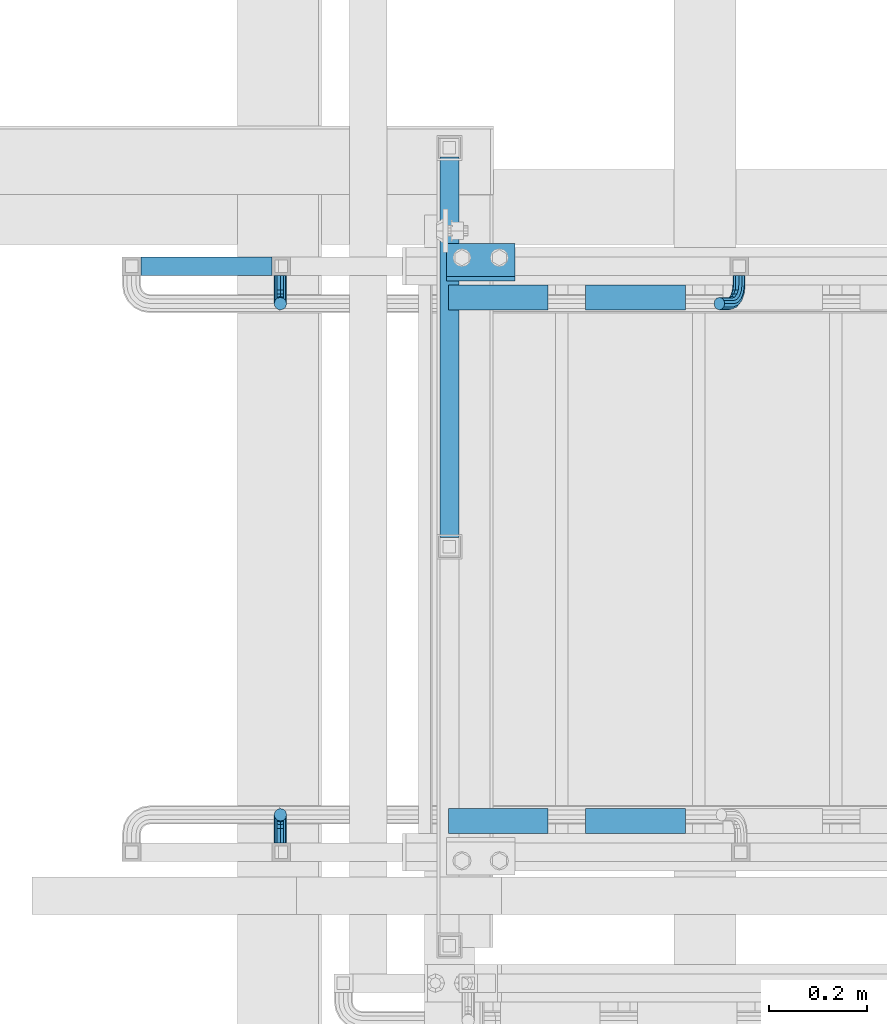
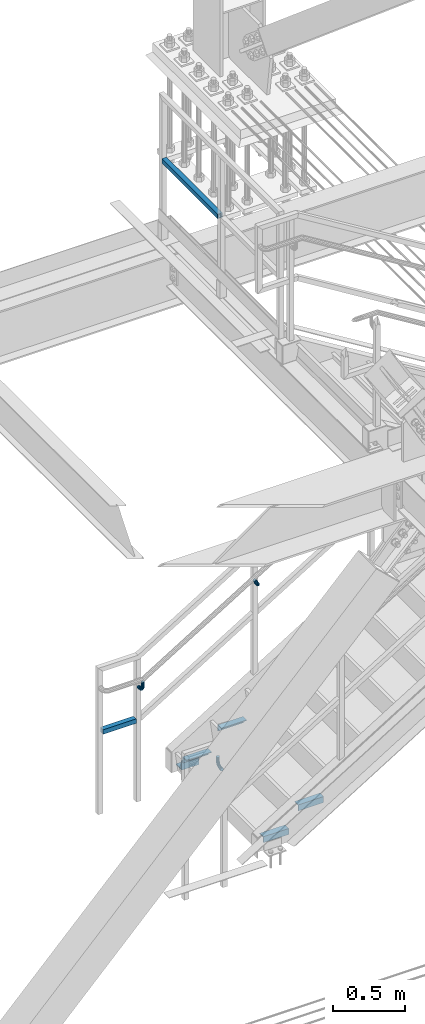
# One storey, part 2585 of 3843: 10 beams, 4 elements without a shape of their own.
"""IFC2X3 building model written with IfcOpenShell, lengths in millimetres."""

from ifc_helpers import new_model, si_unit, frame, origin_with_axes, place, context, subcontext, project, spatial, faceted_brep, material, type_object, element, aggregate, save


model = new_model("IFC2X3")

# Units and contexts
model_context = context("Model", 3, precision=1e-05, world=origin_with_axes())
body_context = subcontext(model_context, "Body", "Model", "MODEL_VIEW")
ifc_project = project(units=[si_unit("LENGTHUNIT", "METRE", prefix="MILLI"), si_unit("AREAUNIT", "SQUARE_METRE"), si_unit("VOLUMEUNIT", "CUBIC_METRE"), si_unit("MASSUNIT", "GRAM", prefix="KILO"), si_unit("TIMEUNIT", "SECOND"), si_unit("PLANEANGLEUNIT", "RADIAN"), si_unit("SOLIDANGLEUNIT", "STERADIAN"), si_unit("THERMODYNAMICTEMPERATUREUNIT", "DEGREE_CELSIUS"), si_unit("LUMINOUSINTENSITYUNIT", "LUMEN")], contexts=[model_context])

# Site, building, storey
site_placement = place(None, origin_with_axes())
site = spatial("IfcSite", under=ifc_project, at=site_placement, CompositionType="ELEMENT")
building_placement = place(site_placement, origin_with_axes())
building = spatial("IfcBuilding", under=site, at=building_placement, Name="Undefined", CompositionType="ELEMENT")
storey_placement = place(building_placement, origin_with_axes())
storey = spatial("IfcBuildingStorey", under=building, at=storey_placement, Name="Undefined", CompositionType="ELEMENT", Elevation=0.0)

# Assembly, beam
assembly_1_placement = place(storey_placement, origin_with_axes())
assembly_1 = element("IfcElementAssembly", 1, at=assembly_1_placement, inside=storey, Name="STAIR", AssemblyPlace="NOTDEFINED", PredefinedType="RIGID_FRAME")
ifc_material_1 = material(Name="STEEL/A36")
beam_type_1 = type_object("IfcBeamType", Name="L3X3X3/8", PredefinedType="NOTDEFINED")
beam_1_placement = place(assembly_1_placement, frame((80803.7500000127, 17927.6375000062, 30518.1), z_axis=(0.0, 1.0, 0.0), x_axis=(1.0, 0.0, 0.0)))
beam_1 = element("IfcBeam", 2, at=beam_1_placement, type_object=beam_type_1, material=ifc_material_1, Name="CLEAT", ObjectType="L3X3X3/8", context=body_context, shape_type="Brep", body=[
    faceted_brep([(0.0, 38.0999999999985, -38.0999999999985), (0.0, 38.0999999999985, 38.0999999999985), (139.699999999997, 38.0999999999985, 38.0999999999985), (139.699999999997, 38.0999999999985, -38.0999999999985), (0.0, 28.5750000000007, 38.0999999999985), (139.699999999997, 28.5750000000007, 38.0999999999985), (0.0, 28.5750000000007, -28.5750000000007), (139.699999999997, 28.5750000000007, -28.5750000000007), (0.0, -38.0999999999985, -28.5750000000007), (139.699999999997, -38.0999999999985, -28.5750000000007), (0.0, -38.0999999999985, -38.0999999999985), (139.699999999997, -38.0999999999985, -38.0999999999985)], [[[0, 1, 2, 3]], [[1, 4, 5, 2]], [[4, 6, 7, 5]], [[6, 8, 9, 7]], [[8, 10, 11, 9]], [[10, 0, 3, 11]], [[5, 7, 9, 11, 3, 2]], [[10, 8, 6, 4, 1, 0]]]),
])

assembly_2_placement = place(storey_placement, origin_with_axes())
assembly_2 = element("IfcElementAssembly", 3, at=assembly_2_placement, inside=storey, Name="RAIL", AssemblyPlace="NOTDEFINED", PredefinedType="RIGID_FRAME")
ifc_material_2 = material()
beam_type_2 = type_object("IfcBeamType", Name="HSS1-1/2X1-1/2X1/4", PredefinedType="NOTDEFINED")
beam_2_placement = place(assembly_2_placement, frame((80162.3999999998, 17919.7, 31013.4000000001), z_axis=(0.0, 0.0, 1.0), x_axis=(1.0, 0.0, 0.0)))
beam_2 = element("IfcBeam", 4, at=beam_2_placement, type_object=beam_type_2, material=ifc_material_2, Name="RAIL", ObjectType="HSS1-1/2X1-1/2X1/4", context=body_context, shape_type="Brep", body=[
    faceted_brep([(285.750000765285, -19.0499992350015, 19.0499992350015), (285.750000765285, -19.0499992350015, -19.0499992350015), (285.750000765285, 19.0499992350015, -19.0499992350015), (285.750000765285, 19.0499992350015, 19.0499992350015), (285.750000765009, -12.6999993300014, 12.6999993299978), (285.750000765009, 12.6999993300014, 12.6999993299978), (285.750000765009, 12.6999993300014, -12.6999993299978), (285.750000765009, -12.6999993300014, -12.6999993299978), (19.0499992350015, 19.0499992350015, -19.0499992350015), (19.0499992350015, 19.0499992350015, 19.0499992350015), (19.0499992350015, -19.0499992350015, 19.0499992350015), (19.0499992350015, -19.0499992350015, -19.0499992350015), (19.0499992350015, 12.6999993299978, 12.6999993299978), (19.0499992350015, -12.6999993299978, 12.6999993299978), (19.0499992350015, -12.6999993299978, -12.6999993299978), (19.0499992350015, 12.6999993299978, -12.6999993299978)], [[[0, 1, 2, 3], [4, 5, 6, 7]], [[8, 9, 3, 2]], [[9, 10, 0, 3]], [[10, 11, 1, 0]], [[11, 8, 2, 1]], [[11, 10, 9, 8], [12, 13, 14, 15]], [[14, 13, 4, 7]], [[15, 14, 7, 6]], [[12, 15, 6, 5]], [[13, 12, 5, 4]]]),
])

assembly_3_placement = place(storey_placement, origin_with_axes())
assembly_3 = element("IfcElementAssembly", 5, at=assembly_3_placement, inside=storey, Name="RAIL", AssemblyPlace="NOTDEFINED", PredefinedType="RIGID_FRAME")
beam_3_placement = place(assembly_3_placement, frame((80810.1, 18167.35, 35483.8), z_axis=(0.0, 0.0, 1.0), x_axis=(0.0, -1.0, 0.0)))
beam_3 = element("IfcBeam", 6, at=beam_3_placement, type_object=beam_type_2, material=ifc_material_2, Name="RAIL", ObjectType="HSS1-1/2X1-1/2X1/4", context=body_context, shape_type="Brep", body=[
    faceted_brep([(800.100000765, -19.0499992349942, 19.0499992350015), (800.100000765, -19.0499992349942, -19.0499992350015), (800.100000765, 19.0499992349942, -19.0499992350015), (800.100000765, 19.0499992349942, 19.0499992350015), (800.100000765, -12.6999993299978, 12.6999993299978), (800.100000765, 12.6999993299978, 12.6999993299978), (800.100000765, 12.6999993299978, -12.6999993299978), (800.100000765, -12.6999993299978, -12.6999993299978), (25.4000000135893, 19.0499992350015, 19.0499992349942), (25.4000000135893, -19.0499992350015, 19.0499992349942), (25.4000000135893, -19.0499992350015, -19.0499992349942), (25.4000000135893, 19.0499992350015, -19.0499992349942), (25.4000000135893, 12.6999993300014, -12.6999993299978), (25.4000000135893, 12.6999993300014, 12.6999993299978), (25.4000000135893, -12.6999993300014, 12.6999993299978), (25.4000000135893, -12.6999993300014, -12.6999993299978)], [[[0, 1, 2, 3], [4, 5, 6, 7]], [[8, 9, 0, 3]], [[10, 11, 2, 1]], [[9, 10, 1, 0]], [[11, 8, 3, 2]], [[11, 10, 9, 8], [12, 13, 14, 15]], [[15, 14, 4, 7]], [[12, 15, 7, 6]], [[13, 12, 6, 5]], [[14, 13, 5, 4]]]),
])
aggregate(assembly_3, [beam_3])

# Beam
ifc_material_3 = material(Name="STEEL/A572-50")
beam_type_3 = type_object("IfcBeamType", Name="L2X2X3/16", PredefinedType="NOTDEFINED")
beam_4_placement = place(assembly_1_placement, frame((81087.5140030505, 17856.1999999907, 30744.5019230761), z_axis=(0.0, -1.0, 0.0), x_axis=(1.0, 0.0, 0.0)))
beam_4 = element("IfcBeam", 7, at=beam_4_placement, type_object=beam_type_3, material=ifc_material_3, Name="ANGLE", ObjectType="L2X2X3/16", context=body_context, shape_type="Brep", body=[
    faceted_brep([(0.0, 25.4000000000015, -25.4000000000015), (0.0, 25.4000000000015, 25.4000000000015), (203.199999999997, 25.4000000000015, 25.4000000000015), (203.199999999997, 25.4000000000015, -25.4000000000015), (0.0, 20.6375000000007, 25.4000000000015), (203.199999999997, 20.6375000000007, 25.4000000000015), (0.0, 20.6375000000007, -20.6375000000007), (203.199999999997, 20.6375000000007, -20.6375000000007), (0.0, -25.4000000000015, -20.6375000000007), (203.199999999997, -25.4000000000015, -20.6375000000007), (0.0, -25.4000000000015, -25.4000000000015), (203.199999999997, -25.4000000000015, -25.4000000000015)], [[[0, 1, 2, 3]], [[1, 4, 5, 2]], [[4, 6, 7, 5]], [[6, 8, 9, 7]], [[8, 10, 11, 9]], [[10, 0, 3, 11]], [[5, 7, 9, 11, 3, 2]], [[10, 8, 6, 4, 1, 0]]]),
])

beam_5_placement = place(assembly_1_placement, frame((81290.7140030505, 16789.3999999318, 30744.5019230761), z_axis=(0.0, 1.0, 0.0), x_axis=(-1.0, 0.0, 0.0)))
beam_5 = element("IfcBeam", 8, at=beam_5_placement, type_object=beam_type_3, material=ifc_material_3, Name="ANGLE", ObjectType="L2X2X3/16", context=body_context, shape_type="Brep", body=[
    faceted_brep([(0.0, 25.4000000000015, -25.4000000000015), (0.0, 25.4000000000015, 25.4000000000015), (203.199999999997, 25.4000000000015, 25.4000000000015), (203.199999999997, 25.4000000000015, -25.4000000000015), (0.0, 20.6375000000007, 25.4000000000015), (203.199999999997, 20.6375000000007, 25.4000000000015), (0.0, 20.6375000000007, -20.6375000000007), (203.199999999997, 20.6375000000007, -20.6375000000007), (0.0, -25.4000000000015, -20.6375000000007), (203.199999999997, -25.4000000000015, -20.6375000000007), (0.0, -25.4000000000015, -25.4000000000015), (203.199999999997, -25.4000000000015, -25.4000000000015)], [[[0, 1, 2, 3]], [[1, 4, 5, 2]], [[4, 6, 7, 5]], [[6, 8, 9, 7]], [[8, 10, 11, 9]], [[10, 0, 3, 11]], [[5, 7, 9, 11, 3, 2]], [[10, 8, 6, 4, 1, 0]]]),
])

beam_6_placement = place(assembly_1_placement, frame((80808.1140030505, 17856.1999999907, 30572.5634615376), z_axis=(0.0, -1.0, 0.0), x_axis=(1.0, 0.0, 0.0)))
beam_6 = element("IfcBeam", 9, at=beam_6_placement, type_object=beam_type_3, material=ifc_material_3, Name="ANGLE", ObjectType="L2X2X3/16", context=body_context, shape_type="Brep", body=[
    faceted_brep([(0.0, 25.4000000000015, -25.4000000000015), (0.0, 25.4000000000015, 25.4000000000015), (203.199999999997, 25.4000000000015, 25.4000000000015), (203.199999999997, 25.4000000000015, -25.4000000000015), (0.0, 20.6375000000007, 25.4000000000015), (203.199999999997, 20.6375000000007, 25.4000000000015), (0.0, 20.6375000000007, -20.6375000000007), (203.199999999997, 20.6375000000007, -20.6375000000007), (0.0, -25.4000000000015, -20.6375000000007), (203.199999999997, -25.4000000000015, -20.6375000000007), (0.0, -25.4000000000015, -25.4000000000015), (203.199999999997, -25.4000000000015, -25.4000000000015)], [[[0, 1, 2, 3]], [[1, 4, 5, 2]], [[4, 6, 7, 5]], [[6, 8, 9, 7]], [[8, 10, 11, 9]], [[10, 0, 3, 11]], [[5, 7, 9, 11, 3, 2]], [[10, 8, 6, 4, 1, 0]]]),
])

beam_7_placement = place(assembly_1_placement, frame((81011.3140030505, 16789.3999999317, 30572.5634615376), z_axis=(0.0, 1.0, 0.0), x_axis=(-1.0, 0.0, 0.0)))
beam_7 = element("IfcBeam", 10, at=beam_7_placement, type_object=beam_type_3, material=ifc_material_3, Name="ANGLE", ObjectType="L2X2X3/16", context=body_context, shape_type="Brep", body=[
    faceted_brep([(0.0, 25.4000000000015, -25.4000000000015), (0.0, 25.4000000000015, 25.4000000000015), (203.199999999997, 25.4000000000015, 25.4000000000015), (203.199999999997, 25.4000000000015, -25.4000000000015), (0.0, 20.6375000000007, 25.4000000000015), (203.199999999997, 20.6375000000007, 25.4000000000015), (0.0, 20.6375000000007, -20.6375000000007), (203.199999999997, 20.6375000000007, -20.6375000000007), (0.0, -25.4000000000015, -20.6375000000007), (203.199999999997, -25.4000000000015, -20.6375000000007), (0.0, -25.4000000000015, -25.4000000000015), (203.199999999997, -25.4000000000015, -25.4000000000015)], [[[0, 1, 2, 3]], [[1, 4, 5, 2]], [[4, 6, 7, 5]], [[6, 8, 9, 7]], [[8, 10, 11, 9]], [[10, 0, 3, 11]], [[5, 7, 9, 11, 3, 2]], [[10, 8, 6, 4, 1, 0]]]),
])

aggregate(assembly_1, [beam_1, beam_4, beam_5, beam_6, beam_7])

beam_type_4 = type_object("IfcBeamType", PredefinedType="NOTDEFINED")
beam_8_placement = place(assembly_2_placement, frame((81399.9812276889, 17900.65, 31856.5785901979), z_axis=(-0.851658316635875, 0.0, -0.524097425775922), x_axis=(0.0, -1.0, 0.0)))
beam_8 = element("IfcBeam", 11, at=beam_8_placement, type_object=beam_type_4, material=ifc_material_1, Name="BRACKET ARM", context=body_context, shape_type="Brep", body=[
    faceted_brep([(0.0, -12.6999999999971, 0.0), (0.0, -10.9985226280696, -6.34999999999854), (19.0500015258731, -10.9985226280623, -6.34999999999854), (19.0500015258731, -12.6999999999971, -6.33008312433958e-10), (0.0, -6.35000000000582, -10.9985226280623), (19.0500015258731, -6.34999999999854, -10.9985226280623), (0.0, 0.0, -12.6999999999971), (19.0500015258731, 0.0, -12.6999999999971), (0.0, 6.35000000000582, -10.9985226280623), (19.0500015258731, 6.34999999999854, -10.9985226280623), (0.0, 10.9985226280696, -6.34999999999854), (19.0500015258731, 10.9985226280623, -6.34999999999854), (0.0, 12.6999999999971, 0.0), (19.0500015258731, 12.6999999999971, 0.0), (0.0, 10.9985226280696, 6.34999999999854), (19.0500015258731, 10.9985226280623, 6.34999999999854), (0.0, 6.35000000000582, 10.9985226280623), (19.0500015258731, 6.34999999999854, 10.9985226280623), (0.0, 0.0, 12.6999999999971), (19.0500015258731, 0.0, 12.6999999999971), (0.0, -6.35000000000582, 10.9985226280623), (19.0500015258731, -6.34999999999854, 10.9985226280623), (0.0, -10.9985226280696, 6.34999999999854), (19.0500015258731, -10.9985226280623, 6.34999999999854), (38.4903193060891, -8.8330803677236, -3.34694050252438e-10), (37.8391921052389, -7.26112024908798, 6.34999999974389), (36.0602795104642, -2.96644533684594, 10.9985226280041), (33.6302397149266, 2.90018969451194, 12.7000000002226), (31.2001999194181, 8.76682472604443, 10.9985226285644), (29.4212873247307, 13.061499638774, 6.35000000070431), (28.7701601240115, 14.6334597580644, 7.78527464717627e-10), (29.4212873248762, 13.0614996394288, -6.34999999929278), (31.2001999196509, 8.76682472718676, -10.9985226275603), (33.6302397151885, 2.90018969582889, -12.6999999997788), (36.0602795106824, -2.96644533571089, -10.9985226281206), (37.8391921053699, -7.26112024843314, -6.35000000026048), (53.7678987435793, 3.38210125690239, -6.3499999994383), (54.9710249311902, 2.17897506880399, 5.0931703299284e-10), (50.4808968708676, 6.66910312997061, -10.9985226273784), (45.9907688103704, 11.1592311906061, -12.6999999991458), (41.5006407498004, 15.6493592510378, -10.9985226270364), (38.213638876914, 18.9363611235749, -6.34999999884167), (37.0105126890558, 20.1394873109457, 1.20053300634027e-09), (38.2136388766667, 18.9363611228473, 6.35000000115542), (41.5006407493784, 15.6493592497718, 10.9985226290883), (45.9907688098756, 11.1592311891436, 12.7000000008557), (50.4808968704456, 6.66910312870459, 10.9985226287463), (53.7678987433319, 3.38210125617479, 6.35000000055879), (64.4111202489148, 19.3108078951118, -6.34999999821594), (65.9830803677178, 18.6596806939051, 1.77533365786076e-09), (60.1164453365491, 21.0897204901557, -10.9985226262725), (54.2498103051475, 23.5197602857806, -12.6999999981927), (48.3831752736587, 25.9498000811873, -10.9985226262434), (44.0885003610601, 27.7287126756128, -6.34999999817228), (42.516540241937, 28.3798398759754, 1.83354131877422e-09), (44.08850036074, 27.7287126747688, 6.35000000183209), (48.3831752731057, 25.9498000797321, 10.9985226298813), (54.2498103045073, 23.5197602840999, 12.7000000018088), (60.1164453359961, 21.0897204886933, 10.9985226298522), (64.4111202485947, 19.3108078942678, 6.35000000178115), (68.1485226282239, 38.0999984746086, -6.3499999967753), (69.8499999999913, 38.0999984741211, 2.92493496090174e-09), (63.500000000291, 38.0999984749651, -10.9985226249628), (57.1500000003434, 38.0999984750961, -12.6999999970722), (50.8000000002939, 38.0999984749651, -10.998522625312), (46.1514773720992, 38.0999984746086, -6.34999999737192), (44.4499999999971, 38.0999984741211, 2.58296495303512e-09), (46.1514773717645, 38.0999984736336, 6.35000000262517), (50.7999999996973, 38.0999984732771, 10.9985226308127), (57.1499999996449, 38.0999984731461, 12.700000002922), (63.4999999996944, 38.0999984732771, 10.9985226311619), (68.1485226278892, 38.0999984736336, 6.35000000322179), (68.1485226280638, 76.2000000002372, -6.34999999414867), (69.8499999999913, 76.199999999757, 5.84986992180347e-09), (63.5, 76.200000000601, -10.9985226222125), (57.1499999999942, 76.2000000007247, -12.6999999941472), (50.7999999999884, 76.200000000601, -10.9985226222125), (46.1514773719246, 76.2000000002372, -6.34999999414867), (44.4499999999971, 76.199999999757, 5.84986992180347e-09), (46.1514773719246, 76.1999999992695, 6.35000000584841), (50.7999999999884, 76.1999999989057, 10.9985226339122), (57.1499999999942, 76.199999998782, 12.700000005847), (63.5, 76.1999999989057, 10.9985226339122), (68.1485226280638, 76.1999999992695, 6.35000000584841)], [[[0, 1, 2, 3]], [[1, 4, 5, 2]], [[4, 6, 7, 5]], [[6, 8, 9, 7]], [[8, 10, 11, 9]], [[10, 12, 13, 11]], [[12, 14, 15, 13]], [[14, 16, 17, 15]], [[16, 18, 19, 17]], [[18, 20, 21, 19]], [[20, 22, 23, 21]], [[22, 0, 3, 23]], [[22, 20, 18, 16, 14, 12, 10, 8, 6, 4, 1, 0]], [[23, 3, 24, 25]], [[21, 23, 25, 26]], [[19, 21, 26, 27]], [[17, 19, 27, 28]], [[15, 17, 28, 29]], [[13, 15, 29, 30]], [[11, 13, 30, 31]], [[9, 11, 31, 32]], [[7, 9, 32, 33]], [[5, 7, 33, 34]], [[2, 5, 34, 35]], [[3, 2, 35, 24]], [[35, 36, 37, 24]], [[34, 38, 36, 35]], [[33, 39, 38, 34]], [[32, 40, 39, 33]], [[31, 41, 40, 32]], [[30, 42, 41, 31]], [[29, 43, 42, 30]], [[28, 44, 43, 29]], [[27, 45, 44, 28]], [[26, 46, 45, 27]], [[25, 47, 46, 26]], [[24, 37, 47, 25]], [[36, 48, 49, 37]], [[38, 50, 48, 36]], [[39, 51, 50, 38]], [[40, 52, 51, 39]], [[41, 53, 52, 40]], [[42, 54, 53, 41]], [[43, 55, 54, 42]], [[44, 56, 55, 43]], [[45, 57, 56, 44]], [[46, 58, 57, 45]], [[47, 59, 58, 46]], [[37, 49, 59, 47]], [[48, 60, 61, 49]], [[50, 62, 60, 48]], [[51, 63, 62, 50]], [[52, 64, 63, 51]], [[53, 65, 64, 52]], [[54, 66, 65, 53]], [[55, 67, 66, 54]], [[56, 68, 67, 55]], [[57, 69, 68, 56]], [[58, 70, 69, 57]], [[59, 71, 70, 58]], [[49, 61, 71, 59]], [[61, 60, 72, 73]], [[60, 62, 74, 72]], [[62, 63, 75, 74]], [[63, 64, 76, 75]], [[64, 65, 77, 76]], [[65, 66, 78, 77]], [[66, 67, 79, 78]], [[67, 68, 80, 79]], [[68, 69, 81, 80]], [[69, 70, 82, 81]], [[70, 71, 83, 82]], [[71, 61, 73, 83]], [[74, 75, 76, 77, 78, 79, 80, 81, 82, 83, 73, 72]]]),
])

beam_9_placement = place(assembly_2_placement, frame((80465.6124994492, 17900.65, 31299.15), z_axis=(-1.0, 0.0, 0.0), x_axis=(0.0, -1.0, 0.0)))
beam_9 = element("IfcBeam", 12, at=beam_9_placement, type_object=beam_type_4, material=ifc_material_1, Name="BRACKET ARM", context=body_context, shape_type="Brep", body=[
    faceted_brep([(0.0, -12.6999999999971, 0.0), (0.0, -10.9985226280696, -6.34999999999854), (19.0500015258731, -10.9985226280623, -6.34999999999854), (19.0500015258731, -12.6999999999971, -6.33008312433958e-10), (0.0, -6.35000000000582, -10.9985226280623), (19.0500015258731, -6.34999999999854, -10.9985226280623), (0.0, 0.0, -12.6999999999971), (19.0500015258731, 0.0, -12.6999999999971), (0.0, 6.35000000000582, -10.9985226280623), (19.0500015258731, 6.34999999999854, -10.9985226280623), (0.0, 10.9985226280696, -6.34999999999854), (19.0500015258731, 10.9985226280623, -6.34999999999854), (0.0, 12.6999999999971, 0.0), (19.0500015258731, 12.6999999999971, 0.0), (0.0, 10.9985226280696, 6.34999999999854), (19.0500015258731, 10.9985226280623, 6.34999999999854), (0.0, 6.35000000000582, 10.9985226280623), (19.0500015258731, 6.34999999999854, 10.9985226280623), (0.0, 0.0, 12.6999999999971), (19.0500015258731, 0.0, 12.6999999999971), (0.0, -6.35000000000582, 10.9985226280623), (19.0500015258731, -6.34999999999854, 10.9985226280623), (0.0, -10.9985226280696, 6.34999999999854), (19.0500015258731, -10.9985226280623, 6.34999999999854), (38.4903193060891, -8.8330803677236, -3.34694050252438e-10), (37.8391921052389, -7.26112024908798, 6.34999999974389), (36.0602795104642, -2.96644533684594, 10.9985226280041), (33.6302397149266, 2.90018969451194, 12.7000000002226), (31.2001999194181, 8.76682472604443, 10.9985226285644), (29.4212873247307, 13.061499638774, 6.35000000070431), (28.7701601240115, 14.6334597580644, 7.78527464717627e-10), (29.4212873248762, 13.0614996394288, -6.34999999929278), (31.2001999196509, 8.76682472718676, -10.9985226275603), (33.6302397151885, 2.90018969582889, -12.6999999997788), (36.0602795106824, -2.96644533571089, -10.9985226281206), (37.8391921053699, -7.26112024843314, -6.35000000026048), (53.7678987435793, 3.38210125690239, -6.3499999994383), (54.9710249311902, 2.17897506880399, 5.0931703299284e-10), (50.4808968708676, 6.66910312997061, -10.9985226273784), (45.9907688103704, 11.1592311906061, -12.6999999991458), (41.5006407498004, 15.6493592510378, -10.9985226270364), (38.213638876914, 18.9363611235749, -6.34999999884167), (37.0105126890558, 20.1394873109457, 1.20053300634027e-09), (38.2136388766667, 18.9363611228473, 6.35000000115542), (41.5006407493784, 15.6493592497718, 10.9985226290883), (45.9907688098756, 11.1592311891436, 12.7000000008557), (50.4808968704456, 6.66910312870459, 10.9985226287463), (53.7678987433319, 3.38210125617479, 6.35000000055879), (64.4111202489148, 19.3108078951118, -6.34999999821594), (65.9830803677178, 18.6596806939051, 1.77533365786076e-09), (60.1164453365491, 21.0897204901557, -10.9985226262725), (54.2498103051475, 23.5197602857806, -12.6999999981927), (48.3831752736587, 25.9498000811873, -10.9985226262434), (44.0885003610601, 27.7287126756128, -6.34999999817228), (42.516540241937, 28.3798398759754, 1.83354131877422e-09), (44.08850036074, 27.7287126747688, 6.35000000183209), (48.3831752731057, 25.9498000797321, 10.9985226298813), (54.2498103045073, 23.5197602840999, 12.7000000018088), (60.1164453359961, 21.0897204886933, 10.9985226298522), (64.4111202485947, 19.3108078942678, 6.35000000178115), (68.1485226282239, 38.0999984746086, -6.3499999967753), (69.8499999999913, 38.0999984741211, 2.92493496090174e-09), (63.500000000291, 38.0999984749651, -10.9985226249628), (57.1500000003434, 38.0999984750961, -12.6999999970722), (50.8000000002939, 38.0999984749651, -10.998522625312), (46.1514773720992, 38.0999984746086, -6.34999999737192), (44.4499999999971, 38.0999984741211, 2.58296495303512e-09), (46.1514773717645, 38.0999984736336, 6.35000000262517), (50.7999999996973, 38.0999984732771, 10.9985226308127), (57.1499999996449, 38.0999984731461, 12.700000002922), (63.4999999996944, 38.0999984732771, 10.9985226311619), (68.1485226278892, 38.0999984736336, 6.35000000322179), (68.1485226280638, 76.2000000002372, -6.34999999414867), (69.8499999999913, 76.199999999757, 5.84986992180347e-09), (63.5, 76.200000000601, -10.9985226222125), (57.1499999999942, 76.2000000007247, -12.6999999941472), (50.7999999999884, 76.200000000601, -10.9985226222125), (46.1514773719246, 76.2000000002372, -6.34999999414867), (44.4499999999971, 76.199999999757, 5.84986992180347e-09), (46.1514773719246, 76.1999999992695, 6.35000000584841), (50.7999999999884, 76.1999999989057, 10.9985226339122), (57.1499999999942, 76.199999998782, 12.700000005847), (63.5, 76.1999999989057, 10.9985226339122), (68.1485226280638, 76.1999999992695, 6.35000000584841)], [[[0, 1, 2, 3]], [[1, 4, 5, 2]], [[4, 6, 7, 5]], [[6, 8, 9, 7]], [[8, 10, 11, 9]], [[10, 12, 13, 11]], [[12, 14, 15, 13]], [[14, 16, 17, 15]], [[16, 18, 19, 17]], [[18, 20, 21, 19]], [[20, 22, 23, 21]], [[22, 0, 3, 23]], [[22, 20, 18, 16, 14, 12, 10, 8, 6, 4, 1, 0]], [[23, 3, 24, 25]], [[21, 23, 25, 26]], [[19, 21, 26, 27]], [[17, 19, 27, 28]], [[15, 17, 28, 29]], [[13, 15, 29, 30]], [[11, 13, 30, 31]], [[9, 11, 31, 32]], [[7, 9, 32, 33]], [[5, 7, 33, 34]], [[2, 5, 34, 35]], [[3, 2, 35, 24]], [[35, 36, 37, 24]], [[34, 38, 36, 35]], [[33, 39, 38, 34]], [[32, 40, 39, 33]], [[31, 41, 40, 32]], [[30, 42, 41, 31]], [[29, 43, 42, 30]], [[28, 44, 43, 29]], [[27, 45, 44, 28]], [[26, 46, 45, 27]], [[25, 47, 46, 26]], [[24, 37, 47, 25]], [[36, 48, 49, 37]], [[38, 50, 48, 36]], [[39, 51, 50, 38]], [[40, 52, 51, 39]], [[41, 53, 52, 40]], [[42, 54, 53, 41]], [[43, 55, 54, 42]], [[44, 56, 55, 43]], [[45, 57, 56, 44]], [[46, 58, 57, 45]], [[47, 59, 58, 46]], [[37, 49, 59, 47]], [[48, 60, 61, 49]], [[50, 62, 60, 48]], [[51, 63, 62, 50]], [[52, 64, 63, 51]], [[53, 65, 64, 52]], [[54, 66, 65, 53]], [[55, 67, 66, 54]], [[56, 68, 67, 55]], [[57, 69, 68, 56]], [[58, 70, 69, 57]], [[59, 71, 70, 58]], [[49, 61, 71, 59]], [[61, 60, 72, 73]], [[60, 62, 74, 72]], [[62, 63, 75, 74]], [[63, 64, 76, 75]], [[64, 65, 77, 76]], [[65, 66, 78, 77]], [[66, 67, 79, 78]], [[67, 68, 80, 79]], [[68, 69, 81, 80]], [[69, 70, 82, 81]], [[70, 71, 83, 82]], [[71, 61, 73, 83]], [[74, 75, 76, 77, 78, 79, 80, 81, 82, 83, 73, 72]]]),
])

aggregate(assembly_2, [beam_2, beam_8, beam_9])

# Assembly, beam
assembly_4_placement = place(storey_placement, origin_with_axes())
assembly_4 = element("IfcElementAssembly", 13, at=assembly_4_placement, inside=storey, Name="RAIL", AssemblyPlace="NOTDEFINED", PredefinedType="RIGID_FRAME")
beam_10_placement = place(assembly_4_placement, frame((80465.6124994492, 16744.95, 31299.15), z_axis=(1.0, 0.0, 0.0), x_axis=(0.0, 1.0, 0.0)))
beam_10 = element("IfcBeam", 14, at=beam_10_placement, type_object=beam_type_4, material=ifc_material_1, Name="BRACKET ARM", context=body_context, shape_type="Brep", body=[
    faceted_brep([(0.0, -12.6999999999971, 0.0), (0.0, -10.9985226280696, -6.34999999999854), (19.0500015258731, -10.9985226280623, -6.34999999999854), (19.0500015258731, -12.6999999999971, -6.33008312433958e-10), (0.0, -6.35000000000582, -10.9985226280623), (19.0500015258731, -6.34999999999854, -10.9985226280623), (0.0, 0.0, -12.6999999999971), (19.0500015258731, 0.0, -12.6999999999971), (0.0, 6.35000000000582, -10.9985226280623), (19.0500015258731, 6.34999999999854, -10.9985226280623), (0.0, 10.9985226280696, -6.34999999999854), (19.0500015258731, 10.9985226280623, -6.34999999999854), (0.0, 12.6999999999971, 0.0), (19.0500015258731, 12.6999999999971, 0.0), (0.0, 10.9985226280696, 6.34999999999854), (19.0500015258731, 10.9985226280623, 6.34999999999854), (0.0, 6.35000000000582, 10.9985226280623), (19.0500015258731, 6.34999999999854, 10.9985226280623), (0.0, 0.0, 12.6999999999971), (19.0500015258731, 0.0, 12.6999999999971), (0.0, -6.35000000000582, 10.9985226280623), (19.0500015258731, -6.34999999999854, 10.9985226280623), (0.0, -10.9985226280696, 6.34999999999854), (19.0500015258731, -10.9985226280623, 6.34999999999854), (38.4903193060891, -8.8330803677236, -3.34694050252438e-10), (37.8391921052389, -7.26112024908798, 6.34999999974389), (36.0602795104642, -2.96644533684594, 10.9985226280041), (33.6302397149266, 2.90018969451194, 12.7000000002226), (31.2001999194181, 8.76682472604443, 10.9985226285644), (29.4212873247307, 13.061499638774, 6.35000000070431), (28.7701601240115, 14.6334597580644, 7.78527464717627e-10), (29.4212873248762, 13.0614996394288, -6.34999999929278), (31.2001999196509, 8.76682472718676, -10.9985226275603), (33.6302397151885, 2.90018969582889, -12.6999999997788), (36.0602795106824, -2.96644533571089, -10.9985226281206), (37.8391921053699, -7.26112024843314, -6.35000000026048), (53.7678987435793, 3.38210125690239, -6.3499999994383), (54.9710249311902, 2.17897506880399, 5.0931703299284e-10), (50.4808968708676, 6.66910312997061, -10.9985226273784), (45.9907688103704, 11.1592311906061, -12.6999999991458), (41.5006407498004, 15.6493592510378, -10.9985226270364), (38.213638876914, 18.9363611235749, -6.34999999884167), (37.0105126890558, 20.1394873109457, 1.20053300634027e-09), (38.2136388766667, 18.9363611228473, 6.35000000115542), (41.5006407493784, 15.6493592497718, 10.9985226290883), (45.9907688098756, 11.1592311891436, 12.7000000008557), (50.4808968704456, 6.66910312870459, 10.9985226287463), (53.7678987433319, 3.38210125617479, 6.35000000055879), (64.4111202489148, 19.3108078951118, -6.34999999821594), (65.9830803677178, 18.6596806939051, 1.77533365786076e-09), (60.1164453365491, 21.0897204901557, -10.9985226262725), (54.2498103051475, 23.5197602857806, -12.6999999981927), (48.3831752736587, 25.9498000811873, -10.9985226262434), (44.0885003610601, 27.7287126756128, -6.34999999817228), (42.516540241937, 28.3798398759754, 1.83354131877422e-09), (44.08850036074, 27.7287126747688, 6.35000000183209), (48.3831752731057, 25.9498000797321, 10.9985226298813), (54.2498103045073, 23.5197602840999, 12.7000000018088), (60.1164453359961, 21.0897204886933, 10.9985226298522), (64.4111202485947, 19.3108078942678, 6.35000000178115), (68.1485226282239, 38.0999984746086, -6.3499999967753), (69.8499999999913, 38.0999984741211, 2.92493496090174e-09), (63.500000000291, 38.0999984749651, -10.9985226249628), (57.1500000003434, 38.0999984750961, -12.6999999970722), (50.8000000002939, 38.0999984749651, -10.998522625312), (46.1514773720992, 38.0999984746086, -6.34999999737192), (44.4499999999971, 38.0999984741211, 2.58296495303512e-09), (46.1514773717645, 38.0999984736336, 6.35000000262517), (50.7999999996973, 38.0999984732771, 10.9985226308127), (57.1499999996449, 38.0999984731461, 12.700000002922), (63.4999999996944, 38.0999984732771, 10.9985226311619), (68.1485226278892, 38.0999984736336, 6.35000000322179), (68.1485226280638, 76.2000000002372, -6.34999999414867), (69.8499999999913, 76.199999999757, 5.84986992180347e-09), (63.5, 76.200000000601, -10.9985226222125), (57.1499999999942, 76.2000000007247, -12.6999999941472), (50.7999999999884, 76.200000000601, -10.9985226222125), (46.1514773719246, 76.2000000002372, -6.34999999414867), (44.4499999999971, 76.199999999757, 5.84986992180347e-09), (46.1514773719246, 76.1999999992695, 6.35000000584841), (50.7999999999884, 76.1999999989057, 10.9985226339122), (57.1499999999942, 76.199999998782, 12.700000005847), (63.5, 76.1999999989057, 10.9985226339122), (68.1485226280638, 76.1999999992695, 6.35000000584841)], [[[0, 1, 2, 3]], [[1, 4, 5, 2]], [[4, 6, 7, 5]], [[6, 8, 9, 7]], [[8, 10, 11, 9]], [[10, 12, 13, 11]], [[12, 14, 15, 13]], [[14, 16, 17, 15]], [[16, 18, 19, 17]], [[18, 20, 21, 19]], [[20, 22, 23, 21]], [[22, 0, 3, 23]], [[22, 20, 18, 16, 14, 12, 10, 8, 6, 4, 1, 0]], [[23, 3, 24, 25]], [[21, 23, 25, 26]], [[19, 21, 26, 27]], [[17, 19, 27, 28]], [[15, 17, 28, 29]], [[13, 15, 29, 30]], [[11, 13, 30, 31]], [[9, 11, 31, 32]], [[7, 9, 32, 33]], [[5, 7, 33, 34]], [[2, 5, 34, 35]], [[3, 2, 35, 24]], [[35, 36, 37, 24]], [[34, 38, 36, 35]], [[33, 39, 38, 34]], [[32, 40, 39, 33]], [[31, 41, 40, 32]], [[30, 42, 41, 31]], [[29, 43, 42, 30]], [[28, 44, 43, 29]], [[27, 45, 44, 28]], [[26, 46, 45, 27]], [[25, 47, 46, 26]], [[24, 37, 47, 25]], [[36, 48, 49, 37]], [[38, 50, 48, 36]], [[39, 51, 50, 38]], [[40, 52, 51, 39]], [[41, 53, 52, 40]], [[42, 54, 53, 41]], [[43, 55, 54, 42]], [[44, 56, 55, 43]], [[45, 57, 56, 44]], [[46, 58, 57, 45]], [[47, 59, 58, 46]], [[37, 49, 59, 47]], [[48, 60, 61, 49]], [[50, 62, 60, 48]], [[51, 63, 62, 50]], [[52, 64, 63, 51]], [[53, 65, 64, 52]], [[54, 66, 65, 53]], [[55, 67, 66, 54]], [[56, 68, 67, 55]], [[57, 69, 68, 56]], [[58, 70, 69, 57]], [[59, 71, 70, 58]], [[49, 61, 71, 59]], [[61, 60, 72, 73]], [[60, 62, 74, 72]], [[62, 63, 75, 74]], [[63, 64, 76, 75]], [[64, 65, 77, 76]], [[65, 66, 78, 77]], [[66, 67, 79, 78]], [[67, 68, 80, 79]], [[68, 69, 81, 80]], [[69, 70, 82, 81]], [[70, 71, 83, 82]], [[71, 61, 73, 83]], [[74, 75, 76, 77, 78, 79, 80, 81, 82, 83, 73, 72]]]),
])
aggregate(assembly_4, [beam_10])

save(model, "model.ifc")
